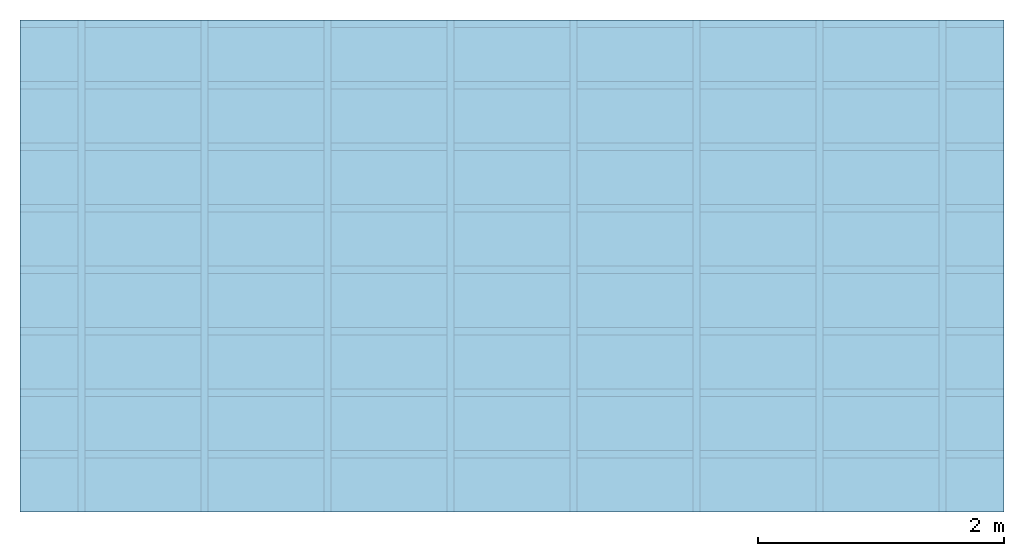
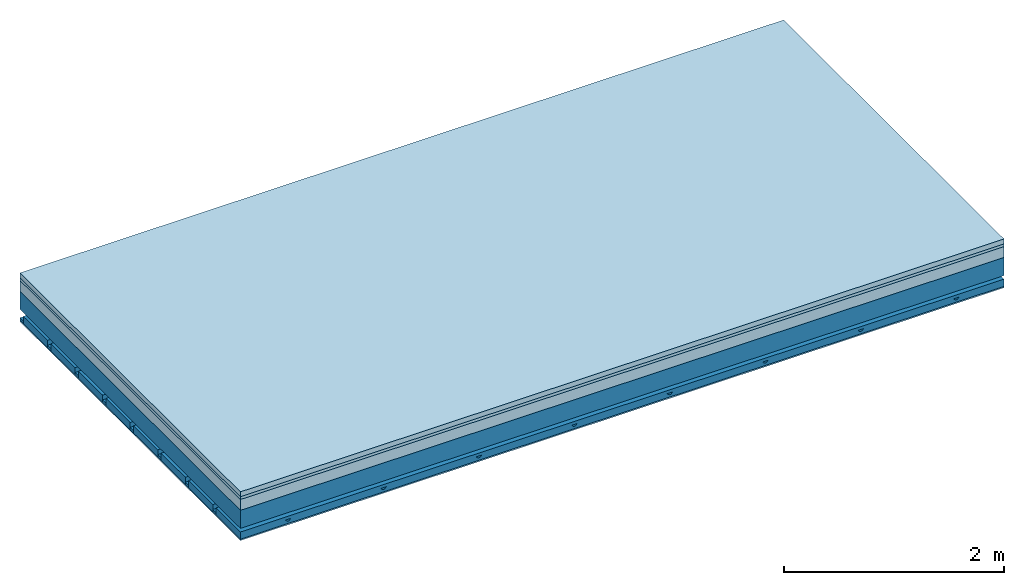
# One storey: 4 members, 4 plates, 1 element without a shape of its own.
"""IFC4 building model written with IfcOpenShell, lengths in metres."""

from ifc_helpers import new_model, si_unit, derived_unit, direction, frame, frame_2d, origin, origin_with_axes, place, context, project, spatial, polyline, rectangle, outline, extrude, material, layer, layer_set, type_object, element, aggregate, save


model = new_model("IFC4")

# Units and contexts
plan_context = context("Plan", 3, precision=1e-05, world=origin(), true_north=direction((0.0, 1.0)))
model_context = context("Model", 3, precision=1e-05, world=origin(), true_north=direction((0.0, 1.0)))
ifc_project = project(units=[si_unit("LENGTHUNIT", "METRE"), derived_unit("SOUNDPRESSUREUNIT", [(si_unit("PRESSUREUNIT", "PASCAL", prefix="MICRO"), 0)]), si_unit("ENERGYUNIT", "JOULE", prefix="MEGA"), si_unit("MASSUNIT", "GRAM", prefix="KILO"), derived_unit("THERMALTRANSMITTANCEUNIT", [(si_unit("POWERUNIT", "WATT"), 1), (si_unit("AREAUNIT", "SQUARE_METRE"), -1), (si_unit("THERMODYNAMICTEMPERATUREUNIT", "KELVIN"), -1)]), derived_unit("AREADENSITYUNIT", [(si_unit("MASSUNIT", "GRAM", prefix="KILO"), 1), (si_unit("AREAUNIT", "SQUARE_METRE"), -1)]), derived_unit("USERDEFINED", [(si_unit("ENERGYUNIT", "JOULE", prefix="MEGA"), 1), (si_unit("AREAUNIT", "SQUARE_METRE"), -1)])], contexts=[plan_context, model_context])

# Site, building, storey
site = spatial("IfcSite", under=ifc_project)
building_placement = place(None, origin())
building = spatial("IfcBuilding", under=site, at=building_placement)
storey_placement = place(building_placement, origin())
storey = spatial("IfcBuildingStorey", under=building, at=storey_placement)

# Slab, members, plates
ifc_material_1 = material(Category="04.005")
ifc_layer_1 = layer(ifc_material_1, 0.055, Name="On-material")
ifc_material_2 = material()
ifc_layer_2 = layer(ifc_material_2, 0.03, Name="Impact sound insulation")
ifc_material_3 = material(Category="03.011")
ifc_layer_3 = layer(ifc_material_3, 0.12, Name="on Supporting structure")
ifc_layer_4 = layer(None, 0.2, Name="Supporting structure")
ifc_material_4 = material(Name="no composite action")
ifc_layer_5 = layer(ifc_material_4, 0.0, Name="Bond")
ifc_layer_6 = layer(None, 0.093, Name="Coupling")
ifc_layer_7 = layer(None, 0.027, Name="Battens / profiles")
ifc_material_5 = material(Category="03.007")
ifc_layer_8 = layer(ifc_material_5, 0.015, Name="Ceiling covering 1st layer")
ifc_material_6 = material(Name="Glued joints")
ifc_layer_9 = layer(ifc_material_6, 0.0, Name="Surface / treatment")
ifc_layer_set = layer_set([ifc_layer_1, ifc_layer_2, ifc_layer_3, ifc_layer_4, ifc_layer_5, ifc_layer_6, ifc_layer_7, ifc_layer_8, ifc_layer_9])
slab_type = type_object("IfcSlabType", Name="A1275", PredefinedType="NOTDEFINED", material=ifc_layer_set)
slab_placement = place(None, frame((0.0, 0.0, 0.0), z_axis=(0.0, 0.0, -1.0), x_axis=(1.0, 0.0, 0.0)))
slab = element("IfcSlab", 1, at=slab_placement, inside=storey, type_object=slab_type, material=ifc_layer_set, Name="Slab #1")
ifc_material_7 = material()
member_1_placement = place(slab_placement, origin())
member_1 = element("IfcMember", 2, at=member_1_placement, material=ifc_material_7, Name="Supporting structure", context=plan_context, shape_type="SweptSolid", body=[
    extrude(rectangle(XDim=1.0, YDim=0.2, at=frame_2d((0.5, 0.1), x_axis=(1.0, 0.0))), frame((0.0, 4.0, 0.205), z_axis=(0.0, -1.0, 0.0), x_axis=(1.0, 0.0, 0.0)), (0.0, 0.0, 1.0), 4.0),
    extrude(rectangle(XDim=1.0, YDim=0.2, at=frame_2d((0.5, 0.1), x_axis=(1.0, 0.0))), frame((1.0, 4.0, 0.205), z_axis=(0.0, -1.0, 0.0), x_axis=(1.0, 0.0, 0.0)), (0.0, 0.0, 1.0), 4.0),
    extrude(rectangle(XDim=1.0, YDim=0.2, at=frame_2d((0.5, 0.1), x_axis=(1.0, 0.0))), frame((2.0, 4.0, 0.205), z_axis=(0.0, -1.0, 0.0), x_axis=(1.0, 0.0, 0.0)), (0.0, 0.0, 1.0), 4.0),
    extrude(rectangle(XDim=1.0, YDim=0.2, at=frame_2d((0.5, 0.1), x_axis=(1.0, 0.0))), frame((3.0, 4.0, 0.205), z_axis=(0.0, -1.0, 0.0), x_axis=(1.0, 0.0, 0.0)), (0.0, 0.0, 1.0), 4.0),
    extrude(rectangle(XDim=1.0, YDim=0.2, at=frame_2d((0.5, 0.1), x_axis=(1.0, 0.0))), frame((4.0, 4.0, 0.205), z_axis=(0.0, -1.0, 0.0), x_axis=(1.0, 0.0, 0.0)), (0.0, 0.0, 1.0), 4.0),
    extrude(rectangle(XDim=1.0, YDim=0.2, at=frame_2d((0.5, 0.1), x_axis=(1.0, 0.0))), frame((5.0, 4.0, 0.205), z_axis=(0.0, -1.0, 0.0), x_axis=(1.0, 0.0, 0.0)), (0.0, 0.0, 1.0), 4.0),
    extrude(rectangle(XDim=1.0, YDim=0.2, at=frame_2d((0.5, 0.1), x_axis=(1.0, 0.0))), frame((6.0, 4.0, 0.205), z_axis=(0.0, -1.0, 0.0), x_axis=(1.0, 0.0, 0.0)), (0.0, 0.0, 1.0), 4.0),
    extrude(rectangle(XDim=1.0, YDim=0.2, at=frame_2d((0.5, 0.1), x_axis=(1.0, 0.0))), frame((7.0, 4.0, 0.205), z_axis=(0.0, -1.0, 0.0), x_axis=(1.0, 0.0, 0.0)), (0.0, 0.0, 1.0), 4.0),
])
ifc_material_8 = material()
member_2_placement = place(slab_placement, origin())
member_2 = element("IfcMember", 3, at=member_2_placement, material=ifc_material_8, Name="Coupling", context=plan_context, shape_type="SweptSolid", body=[
    extrude(outline(polyline([(0.0, 0.0), (0.06, 0.0), (0.04, 0.02), (0.02, 0.02), (0.0, 0.0)])), frame((0.47, 4.0, 0.478), z_axis=(0.0, -1.0, 0.0), x_axis=(1.0, 0.0, 0.0)), (0.0, 0.0, 1.0), 4.0),
    extrude(outline(polyline([(0.0, 0.0), (0.06, 0.0), (0.04, 0.02), (0.02, 0.02), (0.0, 0.0)])), frame((1.47, 4.0, 0.478), z_axis=(0.0, -1.0, 0.0), x_axis=(1.0, 0.0, 0.0)), (0.0, 0.0, 1.0), 4.0),
    extrude(outline(polyline([(0.0, 0.0), (0.06, 0.0), (0.04, 0.02), (0.02, 0.02), (0.0, 0.0)])), frame((2.47, 4.0, 0.478), z_axis=(0.0, -1.0, 0.0), x_axis=(1.0, 0.0, 0.0)), (0.0, 0.0, 1.0), 4.0),
    extrude(outline(polyline([(0.0, 0.0), (0.06, 0.0), (0.04, 0.02), (0.02, 0.02), (0.0, 0.0)])), frame((3.47, 4.0, 0.478), z_axis=(0.0, -1.0, 0.0), x_axis=(1.0, 0.0, 0.0)), (0.0, 0.0, 1.0), 4.0),
    extrude(outline(polyline([(0.0, 0.0), (0.06, 0.0), (0.04, 0.02), (0.02, 0.02), (0.0, 0.0)])), frame((4.47, 4.0, 0.478), z_axis=(0.0, -1.0, 0.0), x_axis=(1.0, 0.0, 0.0)), (0.0, 0.0, 1.0), 4.0),
    extrude(outline(polyline([(0.0, 0.0), (0.06, 0.0), (0.04, 0.02), (0.02, 0.02), (0.0, 0.0)])), frame((5.47, 4.0, 0.478), z_axis=(0.0, -1.0, 0.0), x_axis=(1.0, 0.0, 0.0)), (0.0, 0.0, 1.0), 4.0),
    extrude(outline(polyline([(0.0, 0.0), (0.06, 0.0), (0.04, 0.02), (0.02, 0.02), (0.0, 0.0)])), frame((6.47, 4.0, 0.478), z_axis=(0.0, -1.0, 0.0), x_axis=(1.0, 0.0, 0.0)), (0.0, 0.0, 1.0), 4.0),
    extrude(outline(polyline([(0.0, 0.0), (0.06, 0.0), (0.04, 0.02), (0.02, 0.02), (0.0, 0.0)])), frame((7.47, 4.0, 0.478), z_axis=(0.0, -1.0, 0.0), x_axis=(1.0, 0.0, 0.0)), (0.0, 0.0, 1.0), 4.0),
])
ifc_material_9 = material()
member_3_placement = place(slab_placement, origin())
member_3 = element("IfcMember", 4, at=member_3_placement, material=ifc_material_9, Name="Battens / profiles", context=plan_context, shape_type="SweptSolid", body=[
    extrude(rectangle(XDim=0.06, YDim=0.027, at=frame_2d((0.03, 0.0135), x_axis=(1.0, 0.0))), frame((0.0, 0.0, 0.498), z_axis=(1.0, 0.0, 0.0), x_axis=(0.0, 1.0, 0.0)), (0.0, 0.0, 1.0), 8.0),
    extrude(rectangle(XDim=0.06, YDim=0.027, at=frame_2d((0.03, 0.0135), x_axis=(1.0, 0.0))), frame((0.0, 0.5, 0.498), z_axis=(1.0, 0.0, 0.0), x_axis=(0.0, 1.0, 0.0)), (0.0, 0.0, 1.0), 8.0),
    extrude(rectangle(XDim=0.06, YDim=0.027, at=frame_2d((0.03, 0.0135), x_axis=(1.0, 0.0))), frame((0.0, 1.0, 0.498), z_axis=(1.0, 0.0, 0.0), x_axis=(0.0, 1.0, 0.0)), (0.0, 0.0, 1.0), 8.0),
    extrude(rectangle(XDim=0.06, YDim=0.027, at=frame_2d((0.03, 0.0135), x_axis=(1.0, 0.0))), frame((0.0, 1.5, 0.498), z_axis=(1.0, 0.0, 0.0), x_axis=(0.0, 1.0, 0.0)), (0.0, 0.0, 1.0), 8.0),
    extrude(rectangle(XDim=0.06, YDim=0.027, at=frame_2d((0.03, 0.0135), x_axis=(1.0, 0.0))), frame((0.0, 2.0, 0.498), z_axis=(1.0, 0.0, 0.0), x_axis=(0.0, 1.0, 0.0)), (0.0, 0.0, 1.0), 8.0),
    extrude(rectangle(XDim=0.06, YDim=0.027, at=frame_2d((0.03, 0.0135), x_axis=(1.0, 0.0))), frame((0.0, 2.5, 0.498), z_axis=(1.0, 0.0, 0.0), x_axis=(0.0, 1.0, 0.0)), (0.0, 0.0, 1.0), 8.0),
    extrude(rectangle(XDim=0.06, YDim=0.027, at=frame_2d((0.03, 0.0135), x_axis=(1.0, 0.0))), frame((0.0, 3.0, 0.498), z_axis=(1.0, 0.0, 0.0), x_axis=(0.0, 1.0, 0.0)), (0.0, 0.0, 1.0), 8.0),
    extrude(rectangle(XDim=0.06, YDim=0.027, at=frame_2d((0.03, 0.0135), x_axis=(1.0, 0.0))), frame((0.0, 3.5, 0.498), z_axis=(1.0, 0.0, 0.0), x_axis=(0.0, 1.0, 0.0)), (0.0, 0.0, 1.0), 8.0),
])
ifc_material_10 = material()
member_4_placement = place(slab_placement, origin())
member_4 = element("IfcMember", 5, at=member_4_placement, material=ifc_material_10, Name="Cavity", context=plan_context, shape_type="SweptSolid", body=[
    extrude(rectangle(XDim=0.44, YDim=0.08, at=frame_2d((0.22, 0.04), x_axis=(1.0, 0.0))), frame((0.0, 0.06, 0.445), z_axis=(1.0, 0.0, 0.0), x_axis=(0.0, 1.0, 0.0)), (0.0, 0.0, 1.0), 8.0),
    extrude(rectangle(XDim=0.44, YDim=0.08, at=frame_2d((0.22, 0.04), x_axis=(1.0, 0.0))), frame((0.0, 0.56, 0.445), z_axis=(1.0, 0.0, 0.0), x_axis=(0.0, 1.0, 0.0)), (0.0, 0.0, 1.0), 8.0),
    extrude(rectangle(XDim=0.44, YDim=0.08, at=frame_2d((0.22, 0.04), x_axis=(1.0, 0.0))), frame((0.0, 1.06, 0.445), z_axis=(1.0, 0.0, 0.0), x_axis=(0.0, 1.0, 0.0)), (0.0, 0.0, 1.0), 8.0),
    extrude(rectangle(XDim=0.44, YDim=0.08, at=frame_2d((0.22, 0.04), x_axis=(1.0, 0.0))), frame((0.0, 1.56, 0.445), z_axis=(1.0, 0.0, 0.0), x_axis=(0.0, 1.0, 0.0)), (0.0, 0.0, 1.0), 8.0),
    extrude(rectangle(XDim=0.44, YDim=0.08, at=frame_2d((0.22, 0.04), x_axis=(1.0, 0.0))), frame((0.0, 2.06, 0.445), z_axis=(1.0, 0.0, 0.0), x_axis=(0.0, 1.0, 0.0)), (0.0, 0.0, 1.0), 8.0),
    extrude(rectangle(XDim=0.44, YDim=0.08, at=frame_2d((0.22, 0.04), x_axis=(1.0, 0.0))), frame((0.0, 2.56, 0.445), z_axis=(1.0, 0.0, 0.0), x_axis=(0.0, 1.0, 0.0)), (0.0, 0.0, 1.0), 8.0),
    extrude(rectangle(XDim=0.44, YDim=0.08, at=frame_2d((0.22, 0.04), x_axis=(1.0, 0.0))), frame((0.0, 3.06, 0.445), z_axis=(1.0, 0.0, 0.0), x_axis=(0.0, 1.0, 0.0)), (0.0, 0.0, 1.0), 8.0),
    extrude(rectangle(XDim=0.44, YDim=0.08, at=frame_2d((0.22, 0.04), x_axis=(1.0, 0.0))), frame((0.0, 3.56, 0.445), z_axis=(1.0, 0.0, 0.0), x_axis=(0.0, 1.0, 0.0)), (0.0, 0.0, 1.0), 8.0),
])
plate_1_placement = place(slab_placement, origin())
plate_1 = element("IfcPlate", 6, at=plate_1_placement, material=ifc_material_1, Name="On-material", context=plan_context, shape_type="SweptSolid", body=[
    extrude(rectangle(XDim=8.0, YDim=4.0, at=frame_2d((4.0, 2.0), x_axis=(1.0, 0.0))), origin_with_axes(), (0.0, 0.0, 1.0), 0.055),
])
plate_2_placement = place(slab_placement, origin())
plate_2 = element("IfcPlate", 7, at=plate_2_placement, material=ifc_material_2, Name="Impact sound insulation", context=plan_context, shape_type="SweptSolid", body=[
    extrude(rectangle(XDim=8.0, YDim=4.0, at=frame_2d((4.0, 2.0), x_axis=(1.0, 0.0))), frame((0.0, 0.0, 0.055), z_axis=(0.0, 0.0, 1.0), x_axis=(1.0, 0.0, 0.0)), (0.0, 0.0, 1.0), 0.03),
])
plate_3_placement = place(slab_placement, origin())
plate_3 = element("IfcPlate", 8, at=plate_3_placement, material=ifc_material_3, Name="on Supporting structure", context=plan_context, shape_type="SweptSolid", body=[
    extrude(rectangle(XDim=8.0, YDim=4.0, at=frame_2d((4.0, 2.0), x_axis=(1.0, 0.0))), frame((0.0, 0.0, 0.085), z_axis=(0.0, 0.0, 1.0), x_axis=(1.0, 0.0, 0.0)), (0.0, 0.0, 1.0), 0.12),
])
plate_4_placement = place(slab_placement, origin())
plate_4 = element("IfcPlate", 9, at=plate_4_placement, material=ifc_material_5, Name="Ceiling covering 1st layer", context=plan_context, shape_type="SweptSolid", body=[
    extrude(rectangle(XDim=8.0, YDim=4.0, at=frame_2d((4.0, 2.0), x_axis=(1.0, 0.0))), frame((0.0, 0.0, 0.525), z_axis=(0.0, 0.0, 1.0), x_axis=(1.0, 0.0, 0.0)), (0.0, 0.0, 1.0), 0.015),
])
aggregate(slab, [plate_1, plate_2, plate_3, member_1, member_2, member_3, member_4, plate_4])

save(model, "model.ifc")
